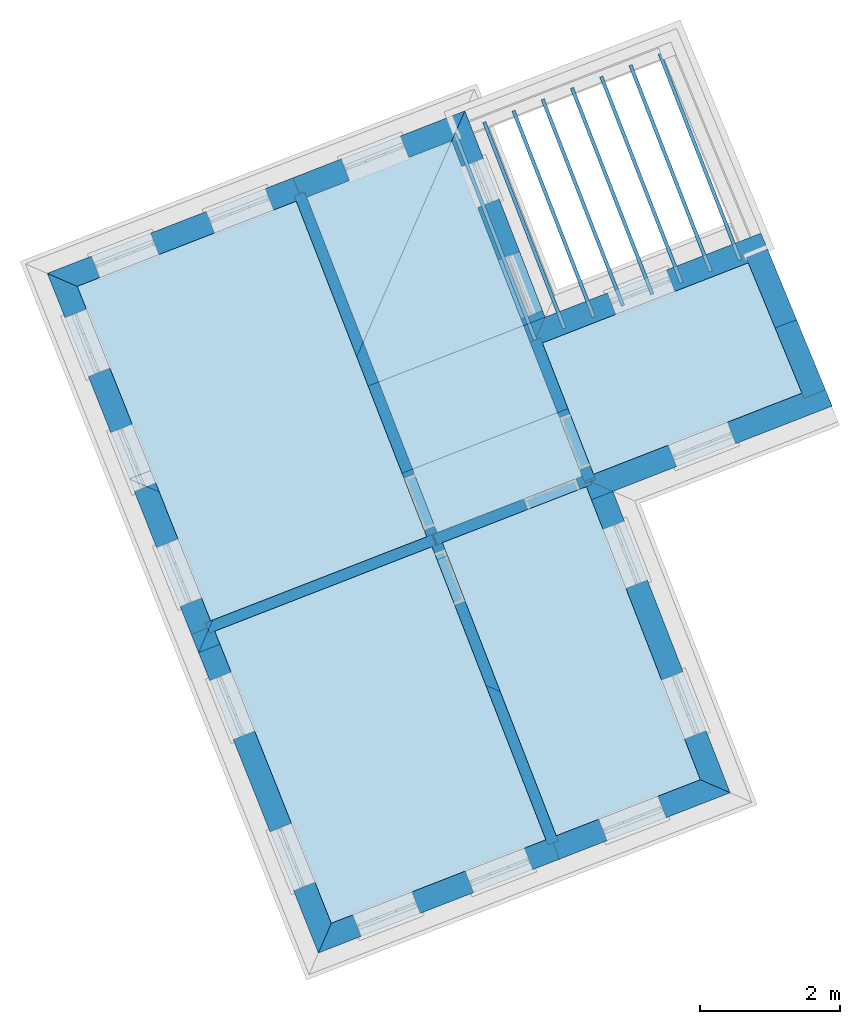
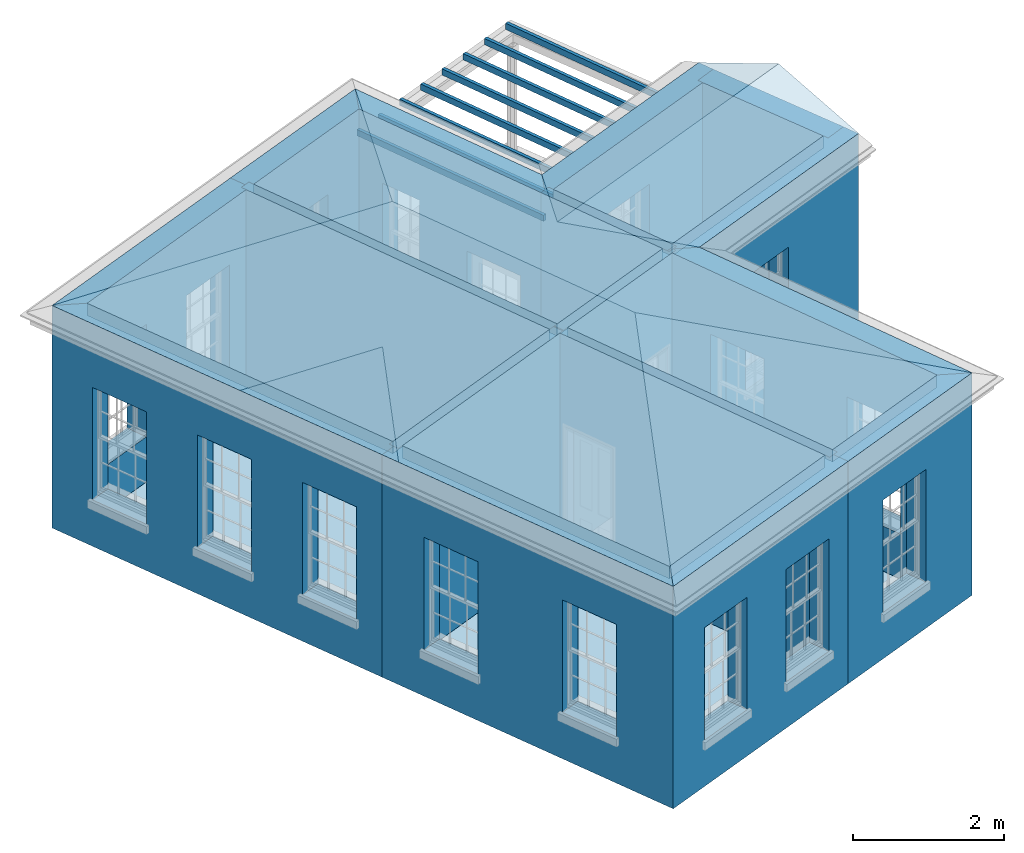
# One storey, part 1 of 11: 18 walls, 17 slabs, 2 roofs, 21 openings.
"""IFC2X3 building model written with IfcOpenShell, lengths in metres."""

from ifc_helpers import new_model, si_unit, frame, origin, place, context, subcontext, project, spatial, polyline, outline, extrude, faceted_brep, material, layer, layer_set, layer_usage, element, save


model = new_model("IFC2X3")

# Units and contexts
model_context = context("Model", 3, world=origin())
body_context = subcontext(model_context, "Body", "Model", "MODEL_VIEW")
ifc_project = project(units=[si_unit("PLANEANGLEUNIT", "RADIAN"), si_unit("MASSUNIT", "GRAM", prefix="KILO"), si_unit("FORCEUNIT", "NEWTON", prefix="KILO"), si_unit("LENGTHUNIT", "METRE")], contexts=[model_context])

# Site, building, storey
site_placement = place(None, origin())
site = spatial("IfcSite", under=ifc_project, at=site_placement, CompositionType="ELEMENT")
building_placement = place(None, origin())
building = spatial("IfcBuilding", under=site, at=building_placement, Name="Building plot-3", CompositionType="ELEMENT")
storey_placement = place(None, frame((0.0, 0.0, 5.45)))
storey = spatial("IfcBuildingStorey", under=building, at=storey_placement, Name="Floor 1", CompositionType="ELEMENT", Elevation=5.45)

# Slabs
slab_1_placement = place(storey_placement, frame((0.0, 0.0, 3.4)))
element("IfcSlab", 1, at=slab_1_placement, inside=storey, Name="Slab", ObjectType="Slab", PredefinedType="FLOOR", context=body_context, shape_type="SweptSolid", body=[
    extrude(outline(polyline([(35.8270146599048, 46.289970963702), (38.9250000592108, 47.4951430621597), (37.0535363264818, 52.3058811523833), (33.9141530388544, 51.0846045300143), (35.8270146599048, 46.289970963702)])), origin(), (0.0, 0.0, 1.0), 0.2),
])
slab_2_placement = place(storey_placement, frame((0.0, 0.0, 3.4)))
element("IfcSlab", 2, at=slab_2_placement, inside=storey, Name="Slab", ObjectType="Slab", PredefinedType="FLOOR", context=body_context, shape_type="SweptSolid", body=[
    extrude(outline(polyline([(40.7817196002938, 43.208843825054), (42.8476670794789, 44.0125345911082), (41.2133491400837, 48.2136716075972), (39.1493349087959, 47.4107329097825), (40.7817196002938, 43.208843825054)])), origin(), (0.0, 0.0, 1.0), 0.2),
])
slab_3_placement = place(storey_placement, frame((0.0, 0.0, 3.4)))
element("IfcSlab", 3, at=slab_3_placement, inside=storey, Name="Slab", ObjectType="Slab", PredefinedType="FLOOR", context=body_context, shape_type="SweptSolid", body=[
    extrude(outline(polyline([(40.5834795798096, 50.2741161079503), (41.3158646777295, 48.3914652044577), (44.3040393730753, 49.5539189619721), (43.5344029070199, 51.4220784125623), (40.5834795798096, 50.2741161079503)])), origin(), (0.0, 0.0, 1.0), 0.2),
])
slab_4_placement = place(storey_placement, frame((0.0, 0.0, 3.4)))
element("IfcSlab", 4, at=slab_4_placement, inside=storey, Name="Slab", ObjectType="Slab", PredefinedType="FLOOR", context=body_context, shape_type="SweptSolid", body=[
    extrude(outline(polyline([(39.0741143020259, 47.5531511873638), (41.1553410148796, 48.3627858504123), (39.2838772821507, 53.1735239406359), (37.2026505692969, 52.3638892775874), (39.0741143020259, 47.5531511873638)])), origin(), (0.0, 0.0, 1.0), 0.2),
])
slab_5_placement = place(storey_placement, frame((0.0, 0.0, 3.4)))
element("IfcSlab", 5, at=slab_5_placement, inside=storey, Name="Slab", ObjectType="Slab", PredefinedType="FLOOR", context=body_context, shape_type="SweptSolid", body=[
    extrude(outline(polyline([(35.8863059592612, 46.1413558987353), (37.5567759813035, 41.9542826933014), (40.6326053416906, 43.1508356937081), (39.0002206501927, 47.3527247784366), (35.8863059592612, 46.1413558987353)])), origin(), (0.0, 0.0, 1.0), 0.2),
])
slab_6_placement = place(storey_placement, frame((0.0, 0.0, 3.1)))
element("IfcSlab", 6, at=slab_6_placement, inside=storey, Name="Slab", ObjectType="Slab", PredefinedType="FLOOR", context=body_context, shape_type="SweptSolid", body=[
    extrude(outline(polyline([(40.4566192953601, 50.3106053971927), (40.5032174962398, 50.3287329363189), (39.352729441396, 53.2861488942086), (39.3061312405163, 53.2680213550823), (40.4566192953601, 50.3106053971927)])), origin(), (0.0, 0.0, 1.0), 0.1),
])
slab_7_placement = place(storey_placement, frame((0.0, 0.0, 3.1)))
element("IfcSlab", 7, at=slab_7_placement, inside=storey, Name="Slab", ObjectType="Slab", PredefinedType="FLOOR", context=body_context, shape_type="SweptSolid", body=[
    extrude(outline(polyline([(40.8760031032775, 50.4737532493291), (40.9226013041572, 50.4918807884554), (39.7721132493134, 53.4492967463451), (39.7255150484337, 53.4311692072188), (40.8760031032775, 50.4737532493291)])), origin(), (0.0, 0.0, 1.0), 0.1),
])
slab_8_placement = place(storey_placement, frame((0.0, 0.0, 3.1)))
element("IfcSlab", 8, at=slab_8_placement, inside=storey, Name="Slab", ObjectType="Slab", PredefinedType="FLOOR", context=body_context, shape_type="SweptSolid", body=[
    extrude(outline(polyline([(41.2953869111949, 50.6369011014656), (41.3419851120746, 50.6550286405919), (40.1914970572307, 53.6124445984816), (40.144898856351, 53.5943170593553), (41.2953869111949, 50.6369011014656)])), origin(), (0.0, 0.0, 1.0), 0.1),
])
slab_9_placement = place(storey_placement, frame((0.0, 0.0, 3.1)))
element("IfcSlab", 9, at=slab_9_placement, inside=storey, Name="Slab", ObjectType="Slab", PredefinedType="FLOOR", context=body_context, shape_type="SweptSolid", body=[
    extrude(outline(polyline([(41.7147707191122, 50.8000489536021), (41.7613689199919, 50.8181764927283), (40.6108808651481, 53.775592450618), (40.5642826642684, 53.7574649114918), (41.7147707191122, 50.8000489536021)])), origin(), (0.0, 0.0, 1.0), 0.1),
])
slab_10_placement = place(storey_placement, frame((0.0, 0.0, 3.1)))
element("IfcSlab", 10, at=slab_10_placement, inside=storey, Name="Slab", ObjectType="Slab", PredefinedType="FLOOR", context=body_context, shape_type="SweptSolid", body=[
    extrude(outline(polyline([(42.1341545270295, 50.9631968057386), (42.1807527279092, 50.9813243448648), (41.0302646730654, 53.9387403027545), (40.9836664721857, 53.9206127636282), (42.1341545270295, 50.9631968057386)])), origin(), (0.0, 0.0, 1.0), 0.1),
])
slab_11_placement = place(storey_placement, frame((0.0, 0.0, 3.1)))
element("IfcSlab", 11, at=slab_11_placement, inside=storey, Name="Slab", ObjectType="Slab", PredefinedType="FLOOR", context=body_context, shape_type="SweptSolid", body=[
    extrude(outline(polyline([(42.5535383349469, 51.126344657875), (42.6001365358266, 51.1444721970013), (41.4496484809828, 54.101888154891), (41.4030502801031, 54.0837606157647), (42.5535383349469, 51.126344657875)])), origin(), (0.0, 0.0, 1.0), 0.1),
])
slab_12_placement = place(storey_placement, frame((0.0, 0.0, 3.1)))
element("IfcSlab", 12, at=slab_12_placement, inside=storey, Name="Slab", ObjectType="Slab", PredefinedType="FLOOR", context=body_context, shape_type="SweptSolid", body=[
    extrude(outline(polyline([(42.9729221428642, 51.2894925100115), (43.0195203437439, 51.3076200491378), (41.8690322889001, 54.2650360070274), (41.8224340880204, 54.2469084679012), (42.9729221428642, 51.2894925100115)])), origin(), (0.0, 0.0, 1.0), 0.1),
])
slab_13_placement = place(storey_placement, frame((0.0, 0.0, 3.1)))
element("IfcSlab", 13, at=slab_13_placement, inside=storey, Name="Slab", ObjectType="Slab", PredefinedType="FLOOR", context=body_context, shape_type="SweptSolid", body=[
    extrude(outline(polyline([(43.3923059507816, 51.452640362148), (43.4389041516613, 51.4707679012743), (42.2884160968175, 54.4281838591639), (42.2418178959378, 54.4100563200376), (43.3923059507816, 51.452640362148)])), origin(), (0.0, 0.0, 1.0), 0.1),
])
slab_14_placement = place(storey_placement, origin())
element("IfcSlab", 14, at=slab_14_placement, inside=storey, Name="Slab", ObjectType="Slab", PredefinedType="FLOOR", context=body_context, shape_type="SweptSolid", body=[
    extrude(outline(polyline([(35.8270146599048, 46.289970963702), (38.9250000592108, 47.4951430621597), (37.0535363264818, 52.3058811523833), (33.9141530388544, 51.0846045300143), (35.8270146599048, 46.289970963702)])), origin(), (0.0, 0.0, 1.0), 0.02),
])
slab_15_placement = place(storey_placement, origin())
element("IfcSlab", 15, at=slab_15_placement, inside=storey, Name="Slab", ObjectType="Slab", PredefinedType="FLOOR", context=body_context, shape_type="SweptSolid", body=[
    extrude(outline(polyline([(40.7817196002938, 43.208843825054), (42.8476670794789, 44.0125345911082), (41.2133491400837, 48.2136716075972), (39.1493349087959, 47.4107329097825), (40.7817196002938, 43.208843825054)])), origin(), (0.0, 0.0, 1.0), 0.02),
])
slab_16_placement = place(storey_placement, origin())
element("IfcSlab", 16, at=slab_16_placement, inside=storey, Name="Slab", ObjectType="Slab", PredefinedType="FLOOR", context=body_context, shape_type="SweptSolid", body=[
    extrude(outline(polyline([(40.5834795798096, 50.2741161079503), (41.3158646777295, 48.3914652044577), (44.3040393730753, 49.5539189619721), (43.5344029070199, 51.4220784125623), (40.5834795798096, 50.2741161079503)])), origin(), (0.0, 0.0, 1.0), 0.02),
])
slab_17_placement = place(storey_placement, origin())
element("IfcSlab", 17, at=slab_17_placement, inside=storey, Name="Slab", ObjectType="Slab", PredefinedType="FLOOR", context=body_context, shape_type="SweptSolid", body=[
    extrude(outline(polyline([(35.8863059592612, 46.1413558987353), (37.5567759813035, 41.9542826933014), (40.6326053416906, 43.1508356937081), (39.0002206501927, 47.3527247784366), (35.8863059592612, 46.1413558987353)])), origin(), (0.0, 0.0, 1.0), 0.02),
])

# Wall, opening
ifc_material_1 = material(Name="Masonry")
ifc_layer_1 = layer(ifc_material_1, 0.33, ventilated=False)
ifc_layer_set_1 = layer_set([ifc_layer_1], Name="My Wall")
ifc_layer_usage_1 = layer_usage(ifc_layer_set_1, "AXIS2", "NEGATIVE", 0.08)
wall_1_placement = place(storey_placement, origin())
wall_1 = element("IfcWallStandardCase", 18, at=wall_1_placement, inside=storey, material=ifc_layer_usage_1, Name="exterior", context=body_context, shape_type="SweptSolid", body=[
    extrude(outline(polyline([(43.840490390188, 51.5411519545112), (43.7208486319546, 51.8487000803173), (40.6222717045672, 50.6432978667857), (40.4343653369945, 50.2161079827462), (43.840490390188, 51.5411519545112)])), origin(), (0.0, 0.0, 1.0), 3.6),
])
opening_1_placement = place(storey_placement, frame((0.0, 0.0, 0.75)))
element("IfcOpeningElement", 19, at=opening_1_placement, cuts=wall_1, Name="Opening", ObjectType="Opening", context=body_context, shape_type="SweptSolid", body=[
    extrude(outline(polyline([(42.3626127918676, 51.3203218839692), (41.514525535857, 50.990400671871), (41.6341672940904, 50.682852546065), (42.4822545501011, 51.0127737581632), (42.3626127918676, 51.3203218839692)])), origin(), (0.0, 0.0, 1.0), 1.82),
])

# Wall, openings
wall_2_placement = place(storey_placement, origin())
wall_2 = element("IfcWallStandardCase", 20, at=wall_2_placement, inside=storey, material=ifc_layer_usage_1, Name="exterior", context=body_context, shape_type="SweptSolid", body=[
    extrude(outline(polyline([(40.4343653369945, 50.2161079827462), (40.6222717045672, 50.6432978667857), (39.4717836497234, 53.6007138246754), (39.2838772821507, 53.1735239406359), (40.4343653369945, 50.2161079827462)])), origin(), (0.0, 0.0, 1.0), 3.6),
])
opening_2_placement = place(storey_placement, frame((0.0, 0.0, 0.0199999999999996)))
element("IfcOpeningElement", 21, at=opening_2_placement, cuts=wall_2, Name="Opening", ObjectType="Opening", context=body_context, shape_type="SweptSolid", body=[
    extrude(outline(polyline([(40.5860166263146, 50.7364942685451), (40.2560954142164, 51.5845815245558), (39.9485472884104, 51.4649397663223), (40.2784685005086, 50.6168525103117), (40.5860166263146, 50.7364942685451)])), origin(), (0.0, 0.0, 1.0), 2.08),
])
opening_3_placement = place(storey_placement, frame((0.0, 0.0, 0.75)))
element("IfcOpeningElement", 22, at=opening_3_placement, cuts=wall_2, Name="Opening", ObjectType="Opening", context=body_context, shape_type="SweptSolid", body=[
    extrude(outline(polyline([(39.9633404786049, 52.3371300753063), (39.7367462395265, 52.9196075863026), (39.4291981137204, 52.7999658280692), (39.6557923527988, 52.2174883170729), (39.9633404786049, 52.3371300753063)])), origin(), (0.0, 0.0, 1.0), 1.82),
])

# Wall, opening
wall_3_placement = place(storey_placement, origin())
wall_3 = element("IfcWallStandardCase", 23, at=wall_3_placement, inside=storey, material=ifc_layer_usage_1, Name="exterior", context=body_context, shape_type="SweptSolid", body=[
    extrude(outline(polyline([(39.2838772821507, 53.1735239406359), (39.4717836497234, 53.6007138246754), (37.0084516896559, 52.6424333407914), (37.1280934478893, 52.3348852149854), (39.2838772821507, 53.1735239406359)])), origin(), (0.0, 0.0, 1.0), 3.6),
])
opening_4_placement = place(storey_placement, frame((0.0, 0.0, 0.75)))
element("IfcOpeningElement", 24, at=opening_4_placement, cuts=wall_3, Name="Opening", ObjectType="Opening", context=body_context, shape_type="SweptSolid", body=[
    extrude(outline(polyline([(38.5476657954957, 53.2412153409668), (37.6995785394851, 52.9112941288686), (37.8192202977185, 52.6037460030626), (38.6673075537291, 52.9336672151608), (38.5476657954957, 53.2412153409668)])), origin(), (0.0, 0.0, 1.0), 1.82),
])

# Wall, openings
wall_4_placement = place(storey_placement, origin())
wall_4 = element("IfcWallStandardCase", 25, at=wall_4_placement, inside=storey, material=ifc_layer_usage_1, Name="exterior", context=body_context, shape_type="SweptSolid", body=[
    extrude(outline(polyline([(37.1280934478893, 52.3348852149854), (37.0084516896559, 52.6424333407914), (33.4843052211603, 51.2714769135402), (33.9141530388544, 51.0846045300143), (37.1280934478893, 52.3348852149854)])), origin(), (0.0, 0.0, 1.0), 3.6),
])
opening_5_placement = place(storey_placement, frame((0.0, 0.0, 0.75)))
element("IfcOpeningElement", 26, at=opening_5_placement, cuts=wall_4, Name="Opening", ObjectType="Opening", context=body_context, shape_type="SweptSolid", body=[
    extrude(outline(polyline([(36.6102098481625, 52.4875100942475), (35.7621225921518, 52.1575888821493), (35.8817643503852, 51.8500407563432), (36.7298516063959, 52.1799619684414), (36.6102098481625, 52.4875100942475)])), origin(), (0.0, 0.0, 1.0), 1.82),
])
opening_6_placement = place(storey_placement, frame((0.0, 0.0, 0.75)))
element("IfcOpeningElement", 27, at=opening_6_placement, cuts=wall_4, Name="Opening", ObjectType="Opening", context=body_context, shape_type="SweptSolid", body=[
    extrude(outline(polyline([(34.9656389091649, 51.8477423890613), (34.1175516531543, 51.5178211769631), (34.2371934113877, 51.210273051157), (35.0852806673983, 51.5401942632552), (34.9656389091649, 51.8477423890613)])), origin(), (0.0, 0.0, 1.0), 1.82),
])

wall_5_placement = place(storey_placement, origin())
wall_5 = element("IfcWallStandardCase", 28, at=wall_5_placement, inside=storey, material=ifc_layer_usage_1, Name="exterior", context=body_context, shape_type="SweptSolid", body=[
    extrude(outline(polyline([(33.9141530388544, 51.0846045300143), (33.4843052211603, 51.2714769135402), (35.5498979859809, 46.0940190694633), (35.8564052090488, 46.2163028468307), (33.9141530388544, 51.0846045300143)])), origin(), (0.0, 0.0, 1.0), 3.6),
])
opening_7_placement = place(storey_placement, frame((0.0, 0.0, 0.75)))
element("IfcOpeningElement", 29, at=opening_7_placement, cuts=wall_5, Name="Opening", ObjectType="Opening", context=body_context, shape_type="SweptSolid", body=[
    extrude(outline(polyline([(33.7378338289687, 50.6360013727893), (34.0750406089818, 49.7907844849356), (34.3815478320497, 49.913068262303), (34.0443410520366, 50.7582851501567), (33.7378338289687, 50.6360013727893)])), origin(), (0.0, 0.0, 1.0), 1.82),
])
opening_8_placement = place(storey_placement, frame((0.0, 0.0, 0.75)))
element("IfcOpeningElement", 30, at=opening_8_placement, cuts=wall_5, Name="Opening", ObjectType="Opening", context=body_context, shape_type="SweptSolid", body=[
    extrude(outline(polyline([(34.395218135771, 48.9882518290296), (34.7324249157841, 48.1430349411759), (35.0389321388519, 48.2653187185433), (34.7017253588388, 49.110535606397), (34.395218135771, 48.9882518290296)])), origin(), (0.0, 0.0, 1.0), 1.82),
])
opening_9_placement = place(storey_placement, frame((0.0, 0.0, 0.75)))
element("IfcOpeningElement", 31, at=opening_9_placement, cuts=wall_5, Name="Opening", ObjectType="Opening", context=body_context, shape_type="SweptSolid", body=[
    extrude(outline(polyline([(35.0526024425732, 47.34050228527), (35.3898092225864, 46.4952853974162), (35.6963164456542, 46.6175691747836), (35.3591096656411, 47.4627860626374), (35.0526024425732, 47.34050228527)])), origin(), (0.0, 0.0, 1.0), 1.82),
])

wall_6_placement = place(storey_placement, origin())
wall_6 = element("IfcWallStandardCase", 32, at=wall_6_placement, inside=storey, material=ifc_layer_usage_1, Name="exterior", context=body_context, shape_type="SweptSolid", body=[
    extrude(outline(polyline([(35.8564052090488, 46.2163028468307), (35.5498979859809, 46.0940190694633), (37.3715047734547, 41.5281179338397), (37.5567759813035, 41.9542826933014), (35.8564052090488, 46.2163028468307)])), origin(), (0.0, 0.0, 1.0), 3.6),
])
opening_10_placement = place(storey_placement, frame((0.0, 0.0, 0.75)))
element("IfcOpeningElement", 33, at=opening_10_placement, cuts=wall_6, Name="Opening", ObjectType="Opening", context=body_context, shape_type="SweptSolid", body=[
    extrude(outline(polyline([(35.8137349263241, 45.43270544579), (36.1509417063372, 44.5874885579362), (36.457448929405, 44.7097723353036), (36.1202421493919, 45.5549892231574), (35.8137349263241, 45.43270544579)])), origin(), (0.0, 0.0, 1.0), 1.82),
])
opening_11_placement = place(storey_placement, frame((0.0, 0.0, 0.75)))
element("IfcOpeningElement", 34, at=opening_11_placement, cuts=wall_6, Name="Opening", ObjectType="Opening", context=body_context, shape_type="SweptSolid", body=[
    extrude(outline(polyline([(36.6786155870234, 43.2648613105897), (37.0158223670365, 42.4196444227359), (37.3223295901044, 42.5419282001033), (36.9851228100912, 43.3871450879571), (36.6786155870234, 43.2648613105897)])), origin(), (0.0, 0.0, 1.0), 1.82),
])

wall_7_placement = place(storey_placement, origin())
wall_7 = element("IfcWallStandardCase", 35, at=wall_7_placement, inside=storey, material=ifc_layer_usage_1, Name="exterior", context=body_context, shape_type="SweptSolid", body=[
    extrude(outline(polyline([(37.5567759813035, 41.9542826933014), (37.3715047734547, 41.5281179338397), (40.8267699200856, 42.8722782867018), (40.7071281618522, 43.1798264125078), (37.5567759813035, 41.9542826933014)])), origin(), (0.0, 0.0, 1.0), 3.6),
])
opening_12_placement = place(storey_placement, frame((0.0, 0.0, 0.75)))
element("IfcOpeningElement", 36, at=opening_12_placement, cuts=wall_7, Name="Opening", ObjectType="Opening", context=body_context, shape_type="SweptSolid", body=[
    extrude(outline(polyline([(37.9845234355629, 41.7665932305832), (38.8326106915735, 42.0965144426814), (38.7129689333401, 42.4040625684875), (37.8648816773295, 42.0741413563893), (37.9845234355629, 41.7665932305832)])), origin(), (0.0, 0.0, 1.0), 1.82),
])
opening_13_placement = place(storey_placement, frame((0.0, 0.0, 0.75)))
element("IfcOpeningElement", 37, at=opening_13_placement, cuts=wall_7, Name="Opening", ObjectType="Opening", context=body_context, shape_type="SweptSolid", body=[
    extrude(outline(polyline([(39.5966586732411, 42.3937428639628), (40.4447459292518, 42.723664076061), (40.3251041710184, 43.0312122018671), (39.4770169150077, 42.7012909897689), (39.5966586732411, 42.3937428639628)])), origin(), (0.0, 0.0, 1.0), 1.82),
])

# Wall, opening
wall_8_placement = place(storey_placement, origin())
wall_8 = element("IfcWallStandardCase", 38, at=wall_8_placement, inside=storey, material=ifc_layer_usage_1, Name="exterior", context=body_context, shape_type="SweptSolid", body=[
    extrude(outline(polyline([(40.7071281618522, 43.1798264125078), (40.8267699200856, 42.8722782867018), (43.2748569635184, 43.8246282235355), (42.8476670794789, 44.0125345911082), (40.7071281618522, 43.1798264125078)])), origin(), (0.0, 0.0, 1.0), 3.6),
])
opening_14_placement = place(storey_placement, frame((0.0, 0.0, 0.75)))
element("IfcOpeningElement", 39, at=opening_14_placement, cuts=wall_8, Name="Opening", ObjectType="Opening", context=body_context, shape_type="SweptSolid", body=[
    extrude(outline(polyline([(41.5102743115974, 43.1381738012539), (42.358361567608, 43.4680950133521), (42.2387198093746, 43.7756431391581), (41.390632553364, 43.4457219270599), (41.5102743115974, 43.1381738012539)])), origin(), (0.0, 0.0, 1.0), 1.82),
])

# Wall, openings
wall_9_placement = place(storey_placement, origin())
wall_9 = element("IfcWallStandardCase", 40, at=wall_9_placement, inside=storey, material=ifc_layer_usage_1, Name="exterior", context=body_context, shape_type="SweptSolid", body=[
    extrude(outline(polyline([(42.8476670794789, 44.0125345911082), (43.2748569635184, 43.8246282235355), (41.5939403189539, 48.1455507116809), (41.1667504349144, 48.3334570792536), (42.8476670794789, 44.0125345911082)])), origin(), (0.0, 0.0, 1.0), 3.6),
])
opening_15_placement = place(storey_placement, frame((0.0, 0.0, 0.75)))
element("IfcOpeningElement", 41, at=opening_15_placement, cuts=wall_9, Name="Opening", ObjectType="Opening", context=body_context, shape_type="SweptSolid", body=[
    extrude(outline(polyline([(42.928950712795, 44.7138062219651), (42.5990295006968, 45.5618934779757), (42.2914813748907, 45.4422517197423), (42.6214025869889, 44.5941644637317), (42.928950712795, 44.7138062219651)])), origin(), (0.0, 0.0, 1.0), 1.82),
])
opening_16_placement = place(storey_placement, frame((0.0, 0.0, 0.75)))
element("IfcOpeningElement", 42, at=opening_16_placement, cuts=wall_9, Name="Opening", ObjectType="Opening", context=body_context, shape_type="SweptSolid", body=[
    extrude(outline(polyline([(42.0884923905128, 46.8742674660378), (41.7585711784145, 47.7223547220484), (41.4510230526085, 47.602712963815), (41.7809442647067, 46.7546257078044), (42.0884923905128, 46.8742674660378)])), origin(), (0.0, 0.0, 1.0), 1.82),
])

# Wall, opening
wall_10_placement = place(storey_placement, origin())
wall_10 = element("IfcWallStandardCase", 43, at=wall_10_placement, inside=storey, material=ifc_layer_usage_1, Name="exterior", context=body_context, shape_type="SweptSolid", body=[
    extrude(outline(polyline([(41.1667504349144, 48.3334570792536), (41.5939403189539, 48.1455507116809), (44.7327190868894, 49.3665921650056), (44.613077328656, 49.6741402908117), (41.1667504349144, 48.3334570792536)])), origin(), (0.0, 0.0, 1.0), 3.6),
])
opening_17_placement = place(storey_placement, frame((0.0, 0.0, 0.75)))
element("IfcOpeningElement", 44, at=opening_17_placement, cuts=wall_10, Name="Opening", ObjectType="Opening", context=body_context, shape_type="SweptSolid", body=[
    extrude(outline(polyline([(42.5062950705178, 48.5004731366628), (43.3543823265284, 48.830394348761), (43.234740568295, 49.1379424745671), (42.3866533122844, 48.8080212624689), (42.5062950705178, 48.5004731366628)])), origin(), (0.0, 0.0, 1.0), 1.82),
])

# Wall
wall_11_placement = place(storey_placement, origin())
element("IfcWallStandardCase", 45, at=wall_11_placement, inside=storey, material=ifc_layer_usage_1, Name="party", context=body_context, shape_type="SweptSolid", body=[
    extrude(outline(polyline([(44.3351216372997, 49.4784721397157), (44.640242729234, 49.6041746427012), (43.8096476655619, 51.6203005492158), (43.5045265736276, 51.4945980462303), (44.3351216372997, 49.4784721397157)])), origin(), (0.0, 0.0, 1.0), 3.6),
])

# Wall, opening
ifc_material_2 = material(Name="Masonry")
ifc_layer_2 = layer(ifc_material_2, 0.16, ventilated=False)
ifc_layer_set_2 = layer_set([ifc_layer_2], Name="My Wall")
ifc_layer_usage_2 = layer_usage(ifc_layer_set_2, "AXIS2", "NEGATIVE", 0.08)
wall_12_placement = place(storey_placement, origin())
wall_12 = element("IfcWallStandardCase", 46, at=wall_12_placement, inside=storey, material=ifc_layer_usage_2, Name="interior", context=body_context, shape_type="SweptSolid", body=[
    extrude(outline(polyline([(39.1203784864176, 47.485269062785), (38.971237565647, 47.4273295619956), (40.6615617640689, 43.0762995407056), (40.8107026848395, 43.134239041495), (39.1203784864176, 47.485269062785)])), origin(), (0.0, 0.0, 1.0), 3.6),
])
opening_18_placement = place(storey_placement, frame((0.0, 0.0, 0.0199999999999996)))
element("IfcOpeningElement", 47, at=opening_18_placement, cuts=wall_12, Name="Opening", ObjectType="Opening", context=body_context, shape_type="SweptSolid", body=[
    extrude(outline(polyline([(39.0364195040351, 47.2595460261288), (39.3261170079822, 46.5138414222763), (39.4752579287527, 46.5717809230657), (39.1855604248056, 47.3174855269182), (39.0364195040351, 47.2595460261288)])), origin(), (0.0, 0.0, 1.0), 2.1),
])

wall_13_placement = place(storey_placement, origin())
wall_13 = element("IfcWallStandardCase", 48, at=wall_13_placement, inside=storey, material=ifc_layer_usage_2, Name="interior", context=body_context, shape_type="SweptSolid", body=[
    extrude(outline(polyline([(41.1843450774817, 48.2882287290048), (41.3334593202967, 48.3462368542088), (40.5544755172075, 50.3486732293578), (40.4053612743925, 50.2906651041538), (41.1843450774817, 48.2882287290048)])), origin(), (0.0, 0.0, 1.0), 3.6),
])
opening_19_placement = place(storey_placement, frame((0.0, 0.0, 0.0199999999999996)))
element("IfcOpeningElement", 49, at=opening_19_placement, cuts=wall_13, Name="Opening", ObjectType="Opening", context=body_context, shape_type="SweptSolid", body=[
    extrude(outline(polyline([(41.2682001794421, 48.5139903773758), (40.9781595534218, 49.2595615914511), (40.8290453106067, 49.201553466247), (41.1190859366271, 48.4559822521717), (41.2682001794421, 48.5139903773758)])), origin(), (0.0, 0.0, 1.0), 2.1),
])

wall_14_placement = place(storey_placement, origin())
wall_14 = element("IfcWallStandardCase", 50, at=wall_14_placement, inside=storey, material=ifc_layer_usage_2, Name="interior", context=body_context, shape_type="SweptSolid", body=[
    extrude(outline(polyline([(39.0168039634303, 47.5308564337978), (39.0748120886343, 47.3817421909828), (41.2879062614912, 48.2426756701993), (41.2298981362872, 48.3917899130143), (39.0168039634303, 47.5308564337978)])), origin(), (0.0, 0.0, 1.0), 3.6),
])
opening_20_placement = place(storey_placement, frame((0.0, 0.0, 0.0199999999999996)))
element("IfcOpeningElement", 51, at=opening_20_placement, cuts=wall_14, Name="Opening", ObjectType="Opening", context=body_context, shape_type="SweptSolid", body=[
    extrude(outline(polyline([(40.374581524249, 47.8873759033243), (41.1201527383243, 48.1774165293447), (41.0621446131202, 48.3265307721597), (40.3165733990449, 48.0364901461393), (40.374581524249, 47.8873759033243)])), origin(), (0.0, 0.0, 1.0), 2.1),
])

# Walls
wall_15_placement = place(storey_placement, origin())
element("IfcWallStandardCase", 52, at=wall_15_placement, inside=storey, material=ifc_layer_usage_2, Name="interior", context=body_context, shape_type="SweptSolid", body=[
    extrude(outline(polyline([(38.9995571806181, 47.5241471247616), (39.0575653058227, 47.3750328819468), (39.0748120886346, 47.3817421909829), (39.01680396343, 47.5308564337977), (38.9995571806181, 47.5241471247616)])), origin(), (0.0, 0.0, 1.0), 3.6),
])
wall_16_placement = place(storey_placement, origin())
element("IfcWallStandardCase", 53, at=wall_16_placement, inside=storey, material=ifc_layer_usage_2, Name="interior", context=body_context, shape_type="SweptSolid", body=[
    extrude(outline(polyline([(41.1957544975164, 48.2588999578462), (41.3448687403316, 48.31690808305), (41.3334593202968, 48.3462368542087), (41.1843450774816, 48.2882287290049), (41.1957544975164, 48.2588999578462)])), origin(), (0.0, 0.0, 1.0), 3.6),
])
wall_17_placement = place(storey_placement, origin())
element("IfcWallStandardCase", 54, at=wall_17_placement, inside=storey, material=ifc_layer_usage_2, Name="interior", context=body_context, shape_type="SweptSolid", body=[
    extrude(outline(polyline([(39.0575653058224, 47.3750328819467), (38.9995571806184, 47.5241471247617), (35.753096365097, 46.2612154161491), (35.811104490301, 46.1121011733341), (39.0575653058224, 47.3750328819467)])), origin(), (0.0, 0.0, 1.0), 3.6),
])

# Wall, opening
wall_18_placement = place(storey_placement, origin())
wall_18 = element("IfcWallStandardCase", 55, at=wall_18_placement, inside=storey, material=ifc_layer_usage_2, Name="interior", context=body_context, shape_type="SweptSolid", body=[
    extrude(outline(polyline([(38.9540041218129, 47.4205859407522), (39.1031183646279, 47.4785940659562), (37.1736465066948, 52.4384463989949), (37.0245322638798, 52.3804382737909), (38.9540041218129, 47.4205859407522)])), origin(), (0.0, 0.0, 1.0), 3.6),
])
opening_21_placement = place(storey_placement, frame((0.0, 0.0, 0.0199999999999996)))
element("IfcOpeningElement", 56, at=opening_21_placement, cuts=wall_18, Name="Opening", ObjectType="Opening", context=body_context, shape_type="SweptSolid", body=[
    extrude(outline(polyline([(39.0378592237733, 47.6463475891232), (38.7478185977529, 48.3919188031985), (38.5987043549379, 48.3339106779944), (38.8887449809583, 47.5883394639191), (39.0378592237733, 47.6463475891232)])), origin(), (0.0, 0.0, 1.0), 2.1),
])

# Roofs
roof_1_placement = place(building_placement, origin())
element("IfcRoof", 57, at=roof_1_placement, inside=storey, Name="Roof", ShapeType="FREEFORM", context=body_context, shape_type="Brep", held_by="IfcProductRepresentation", body=[
    faceted_brep([(43.274857, 43.824628, 9.05), (39.471784, 53.600714, 9.05), (37.650533, 49.460248, 10.374849), (39.157285, 45.635809, 10.367524), (33.484305, 51.271477, 9.05), (37.371505, 41.528118, 9.05)], [[[0, 1, 2, 3]], [[4, 5, 3, 2]], [[5, 4, 1, 0]], [[5, 0, 3]], [[1, 4, 2]]]),
])
roof_2_placement = place(building_placement, origin())
element("IfcRoof", 58, at=roof_2_placement, inside=storey, Name="Roof", ShapeType="FREEFORM", context=body_context, shape_type="Brep", held_by="IfcProductRepresentation", body=[
    faceted_brep([(35.653405, 45.834576, 9.05), (44.737375, 49.368403, 9.05), (44.226829, 50.607664, 9.605065), (36.405744, 47.565121, 9.605065), (43.716284, 51.846924, 9.05), (34.660243, 48.323961, 9.05)], [[[0, 1, 2, 3]], [[4, 5, 3, 2]], [[5, 4, 1, 0]], [[5, 0, 3]], [[1, 4, 2]]]),
])

save(model, "model.ifc")
